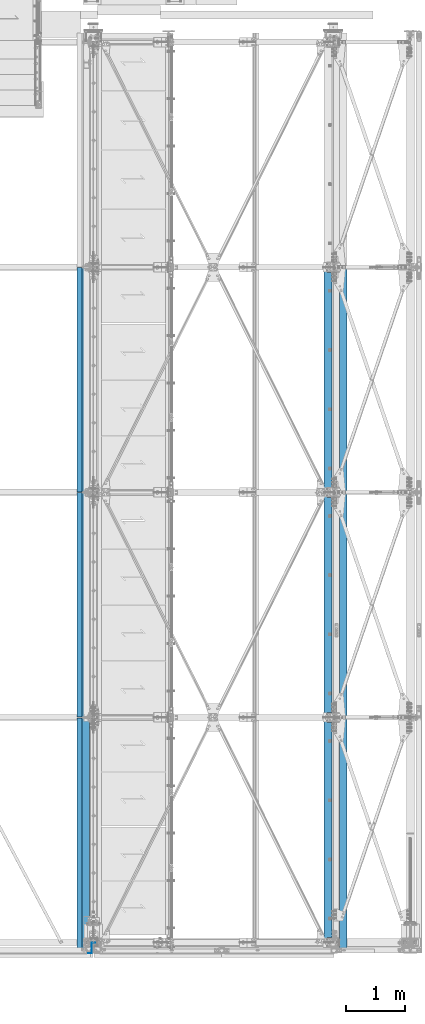
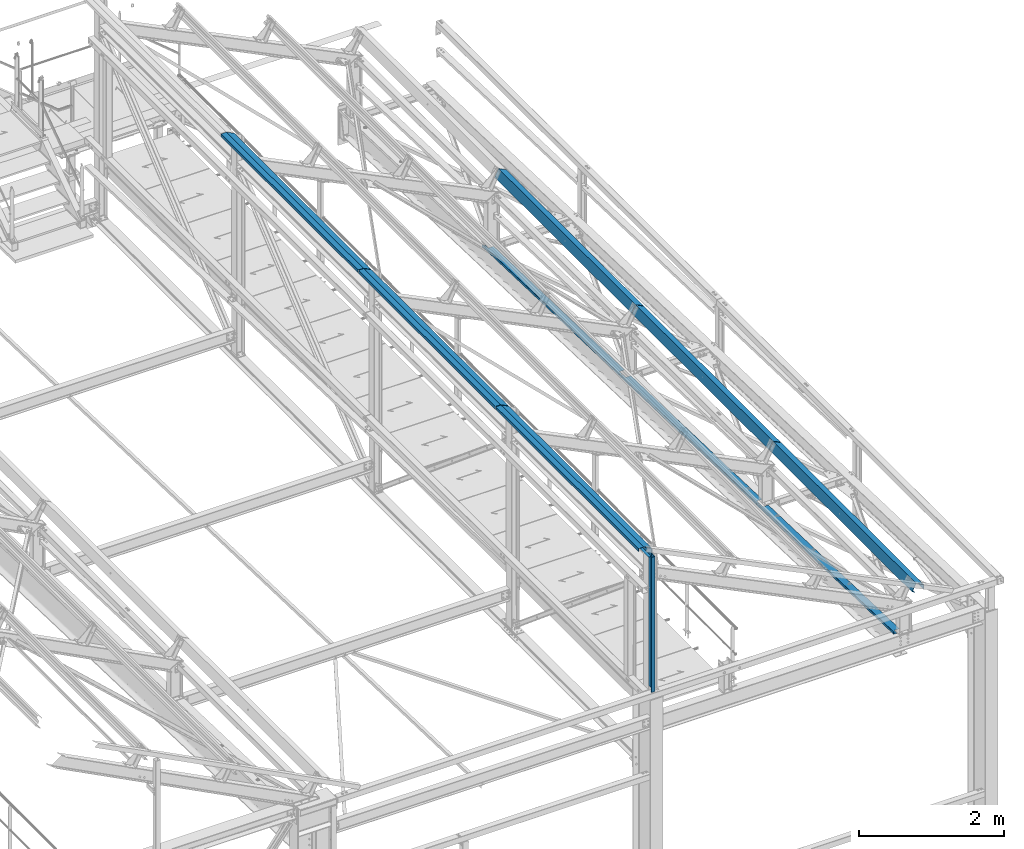
# One storey, part 351 of 496: 10 beams, 10 elements without a shape of their own.
"""IFC2X3 building model written with IfcOpenShell, lengths in millimetres."""

import ifcopenshell
import ifcopenshell.guid

model = None  # the IFC model being written
_history = None  # IfcOwnerHistory: only IFC2X3 demands one
_inside = {}  # id of a spatial element -> (the spatial element, [elements in it])
_under = {}  # id of a project, library or spatial element -> (it, [spatial elements below it])
_declared = {}  # id of a project -> (the project, [libraries it declares])
_typed = {}  # id of a type object -> (the type object, [elements of that type])
_made_of = {}  # id of a material, layer set ... -> (it, [elements and type objects made of it])


def new_model(schema):
    """Start an empty IFC model of exactly this schema.

    Asked for "IFC4X3", IfcOpenShell would pick the latest addendum, in which some entities
    have other attributes; the version numbers below select the first issue.
    IFC2X3 requires an IfcOwnerHistory on every rooted entity: one is made here for all.
    """
    global model, _history
    if schema == "IFC4X3":
        model = ifcopenshell.file(schema_version=(4, 3, 0, 0))
    else:
        model = ifcopenshell.file(schema=schema)
    _inside.clear()
    _under.clear()
    _declared.clear()
    _typed.clear()
    _made_of.clear()
    _history = None
    if model.schema == "IFC2X3":
        org = make("IfcOrganization", Name="unknown")
        user = make(
            "IfcPersonAndOrganization",
            ThePerson=make("IfcPerson", FamilyName="unknown"),
            TheOrganization=org,
        )
        app = make(
            "IfcApplication",
            ApplicationDeveloper=org,
            Version="unknown",
            ApplicationFullName="unknown",
            ApplicationIdentifier="unknown",
        )
        _history = make(
            "IfcOwnerHistory",
            OwningUser=user,
            OwningApplication=app,
            ChangeAction="ADDED",
            CreationDate=0,
        )
    return model


def make(cls, **values):
    """One entity of the class cls with the attributes given. An attribute that is None is left unset."""
    return model.create_entity(
        cls, **{name: value for name, value in values.items() if value is not None}
    )


def rooted(cls, **values):
    """An entity with a GlobalId (a new one), such as an element, a storey or a relation."""
    return make(cls, GlobalId=ifcopenshell.guid.new(), OwnerHistory=_history, **values)


def si_unit(unit_type, name, prefix=None):
    """IfcSIUnit, for example si_unit("LENGTHUNIT", "METRE", prefix="MILLI")."""
    return make("IfcSIUnit", UnitType=unit_type, Prefix=prefix, Name=name)


def assignment(units):
    """IfcUnitAssignment: the units of a project."""
    return None if units is None else make("IfcUnitAssignment", Units=units)


def point(xyz):
    """IfcCartesianPoint."""
    return None if xyz is None else make("IfcCartesianPoint", Coordinates=xyz)


def direction(xyz):
    """IfcDirection."""
    return None if xyz is None else make("IfcDirection", DirectionRatios=xyz)


def frame(location, z_axis=None, x_axis=None):
    """IfcAxis2Placement3D, a coordinate frame: its origin and axes. An axis left out is left unset."""
    return make(
        "IfcAxis2Placement3D",
        Location=point(location),
        Axis=direction(z_axis),
        RefDirection=direction(x_axis),
    )


def origin_with_axes():
    """The frame at (0, 0, 0) with the z axis (0, 0, 1) and the x axis (1, 0, 0) written out."""
    return frame((0.0, 0.0, 0.0), z_axis=(0.0, 0.0, 1.0), x_axis=(1.0, 0.0, 0.0))


def place(relative_to, where):
    """IfcLocalPlacement: puts the frame where relative to a parent placement (None: the world)."""
    return make(
        "IfcLocalPlacement", PlacementRelTo=relative_to, RelativePlacement=where
    )


def context(
    kind, dimensions, precision=None, world=None, true_north=None, identifier=None
):
    """IfcGeometricRepresentationContext, for example the 3D "Model" context."""
    return make(
        "IfcGeometricRepresentationContext",
        ContextIdentifier=identifier,
        ContextType=kind,
        CoordinateSpaceDimension=dimensions,
        Precision=precision,
        WorldCoordinateSystem=world,
        TrueNorth=true_north,
    )


def subcontext(parent, identifier, kind, view, scale=None):
    """IfcGeometricRepresentationSubContext, for example "Body" below "Model"."""
    return make(
        "IfcGeometricRepresentationSubContext",
        ContextIdentifier=identifier,
        ContextType=kind,
        ParentContext=parent,
        TargetScale=scale,
        TargetView=view,
    )


def project(units=None, contexts=None):
    """IfcProject with its units and contexts."""
    return rooted(
        "IfcProject",
        Name="project",
        RepresentationContexts=contexts,
        UnitsInContext=assignment(units),
    )


def spatial(cls, under=None, at=None, **own):
    """A site, building, storey or space (cls), placed at a placement, below another one or the project."""
    s = rooted(cls, ObjectPlacement=at, **own)
    if under is not None:
        _under.setdefault(under.id(), (under, []))[1].append(s)
    return s


def faces_of(points, faces, orient=None, outer=None):
    """IfcFace entities. A face is a list of loops; a loop is a list of indices into points, from 0.

    orient and outer hold one flag for each loop. By default every Orientation is true, the
    first loop of a face is its IfcFaceOuterBound and the others are IfcFaceBound.
    """
    made = []
    for i, loops in enumerate(faces):
        bounds = []
        for j, loop in enumerate(loops):
            is_outer = j == 0 if outer is None else outer[i][j]
            bounds.append(
                make(
                    "IfcFaceOuterBound" if is_outer else "IfcFaceBound",
                    Bound=make("IfcPolyLoop", Polygon=[points[k] for k in loop]),
                    Orientation=True if orient is None else orient[i][j],
                )
            )
        made.append(make("IfcFace", Bounds=bounds))
    return made


def faceted_brep(points, faces, orient=None, outer=None, voids=None):
    """IfcFacetedBrep: a solid bounded by flat faces; with voids (closed shells), ...WithVoids."""
    shared = [point(p) for p in points]
    hull = make("IfcClosedShell", CfsFaces=faces_of(shared, faces, orient, outer))
    if voids is None:
        return make("IfcFacetedBrep", Outer=hull)
    return make(
        "IfcFacetedBrepWithVoids",
        Outer=hull,
        Voids=[
            make(cls, CfsFaces=faces_of(shared, fs, o, b)) for cls, fs, o, b in voids
        ],
    )


def shape(context_of_items, identifier, shape_type, items):
    """IfcShapeRepresentation: the items that make up one representation, for example the "Body"."""
    return make(
        "IfcShapeRepresentation",
        ContextOfItems=context_of_items,
        RepresentationIdentifier=identifier,
        RepresentationType=shape_type,
        Items=items,
    )


def material(Name=None, Category=None):
    """IfcMaterial."""
    return make("IfcMaterial", Name=Name, Category=Category)


def made_of(thing, what):
    """Note that an element or type object is made of a material, layer set ...; save() writes the relation."""
    if what is not None:
        _made_of.setdefault(what.id(), (what, []))[1].append(thing)
    return thing


def type_object(cls, material=None, **own):
    """A type object (cls), such as IfcWallType, which elements share."""
    return made_of(rooted(cls, **own), material)


def element(
    cls,
    number,
    at=None,
    inside=None,
    cuts=None,
    type_object=None,
    material=None,
    context=None,
    identifier="Body",
    shape_type=None,
    held_by="IfcProductDefinitionShape",
    body=None,
    shapes=None,
    **own,
):
    """One element of the class cls, such as IfcWall. Its Tag is "e" and its number.

    at: its placement. inside: the storey or other place that contains it. cuts: it is an
    opening in that element (IfcRelVoidsElement). A single representation is given by context,
    identifier, shape_type and body (its items); several are given by shapes. held_by: the class
    of the entity that holds the representations. save() writes the other relations.
    """
    e = rooted(cls, Tag="e%d" % number, ObjectPlacement=at, **own)
    if body is not None:
        shapes = [shape(context, identifier, shape_type, body)]
    if shapes is not None:
        e.Representation = make(held_by, Representations=shapes)
    if inside is not None:
        _inside.setdefault(inside.id(), (inside, []))[1].append(e)
    if cuts is not None:
        rooted(
            "IfcRelVoidsElement", RelatingBuildingElement=cuts, RelatedOpeningElement=e
        )
    if type_object is not None:
        _typed.setdefault(type_object.id(), (type_object, []))[1].append(e)
    return made_of(e, material)


def aggregate(whole, parts):
    """IfcRelAggregates: a whole, such as a stair, and the parts it consists of."""
    return rooted("IfcRelAggregates", RelatingObject=whole, RelatedObjects=parts)


def save(model, path):
    """Write the relations noted so far, then the file.

    IfcRelAggregates (storeys below a building ...), IfcRelContainedInSpatialStructure (elements
    in a storey), IfcRelDefinesByType, IfcRelAssociatesMaterial and IfcRelDeclares: one each for
    every whole, place, type object, material and project.
    """
    for whole, parts in _under.values():
        aggregate(whole, parts)
    for where, things in _inside.values():
        rooted(
            "IfcRelContainedInSpatialStructure",
            RelatedElements=things,
            RelatingStructure=where,
        )
    for kind, things in _typed.values():
        rooted("IfcRelDefinesByType", RelatedObjects=things, RelatingType=kind)
    for what, things in _made_of.values():
        rooted("IfcRelAssociatesMaterial", RelatedObjects=things, RelatingMaterial=what)
    for by, libraries in _declared.values():
        rooted("IfcRelDeclares", RelatingContext=by, RelatedDefinitions=libraries)
    model.write(path)


model = new_model("IFC2X3")

# Units and contexts
model_context = context("Model", 3, precision=1e-05, world=origin_with_axes())
body_context = subcontext(model_context, "Body", "Model", "MODEL_VIEW")
ifc_project = project(units=[si_unit("LENGTHUNIT", "METRE", prefix="MILLI"), si_unit("AREAUNIT", "SQUARE_METRE"), si_unit("VOLUMEUNIT", "CUBIC_METRE"), si_unit("MASSUNIT", "GRAM", prefix="KILO"), si_unit("TIMEUNIT", "SECOND"), si_unit("PLANEANGLEUNIT", "RADIAN"), si_unit("SOLIDANGLEUNIT", "STERADIAN"), si_unit("THERMODYNAMICTEMPERATUREUNIT", "DEGREE_CELSIUS"), si_unit("LUMINOUSINTENSITYUNIT", "LUMEN")], contexts=[model_context])

# Site, building, storey
site_placement = place(None, origin_with_axes())
site = spatial("IfcSite", under=ifc_project, at=site_placement, CompositionType="ELEMENT")
building_placement = place(site_placement, origin_with_axes())
building = spatial("IfcBuilding", under=site, at=building_placement, Name="Undefined", CompositionType="ELEMENT")
storey_placement = place(building_placement, origin_with_axes())
storey = spatial("IfcBuildingStorey", under=building, at=storey_placement, Name="Undefined", CompositionType="ELEMENT", Elevation=0.0)

# Assembly, beam
assembly_1_placement = place(storey_placement, origin_with_axes())
assembly_1 = element("IfcElementAssembly", 1, at=assembly_1_placement, inside=storey, Name="SHED", AssemblyPlace="NOTDEFINED", PredefinedType="NOTDEFINED")
ifc_material = material(Name="Undefined/S235-E24")
beam_type_1 = type_object("IfcBeamType", PredefinedType="NOTDEFINED")
beam_1_placement = place(assembly_1_placement, frame((38418.1250345939, 9500.00038595282, 8769.23312698683), z_axis=(0.0, 1.0, 0.0), x_axis=(-0.897398510539055, -1.29999898490537e-08, 0.441220934773368)))
beam_1 = element("IfcBeam", 2, at=beam_1_placement, type_object=beam_type_1, material=ifc_material, Name="SHED", context=body_context, shape_type="Brep", body=[
    faceted_brep([(-3.49427864421159e-08, -1.49999999999636, -1895.0), (-3.52956703864038e-08, -1.5, 1895.0), (3.49573383573443e-08, 1.5, 1895.0), (3.53102223016322e-08, 1.5, -1895.0), (47.0000011861484, 1.499998899395, 1895.0), (47.0000011898519, 1.49999889939863, -1895.0), (50.0000011927114, -1.50000117085074, -1895.0), (50.0000011890152, -1.50000117085438, 1895.0), (47.000001059947, 135.500002207569, 1895.00000000012), (47.0000010603762, 135.500002214732, -1894.99999999988), (50.0000010575095, 138.500002217588, -1894.99999999987), (50.0000010570839, 138.500002210421, 1895.00000000013), (-88.1320086650667, 135.500006400751, 1895.00000000041), (-88.1320086733285, 135.500006406346, -1894.99999999959), (-90.0000023299144, 138.50000208251, -1894.99999999975), (-90.0000023251705, 138.500002079061, 1895.00000000025), (-122.605485965658, 65.3844594190341, 1895.00000000043), (-122.605485972435, 65.3844594213988, -1894.99999999957), (-125.297681497275, 66.7081222233501, 1895.00000000044), (-125.297681504053, 66.7081222257148, -1894.99999999956)], [[[0, 1, 2, 3]], [[3, 2, 4, 5]], [[1, 0, 6, 7]], [[5, 4, 8, 9]], [[7, 6, 10, 11]], [[9, 8, 12, 13]], [[11, 10, 14, 15]], [[13, 12, 16, 17]], [[12, 8, 4, 2, 1, 7, 11, 15, 18, 16]], [[15, 14, 19, 18]], [[14, 10, 6, 0, 3, 5, 9, 13, 17, 19]], [[18, 19, 17, 16]]]),
])
aggregate(assembly_1, [beam_1])

assembly_2_placement = place(storey_placement, origin_with_axes())
assembly_2 = element("IfcElementAssembly", 3, at=assembly_2_placement, inside=storey, Name="SHED", AssemblyPlace="NOTDEFINED", PredefinedType="NOTDEFINED")
beam_2_placement = place(assembly_2_placement, frame((38418.1250345939, 5700.00038595282, 8769.23312698683), z_axis=(0.0, 1.0, 0.0), x_axis=(-0.897398510539055, -1.29999898490537e-08, 0.441220934773368)))
beam_2 = element("IfcBeam", 4, at=beam_2_placement, type_object=beam_type_1, material=ifc_material, Name="SHED", context=body_context, shape_type="Brep", body=[
    faceted_brep([(-3.49427864421159e-08, -1.49999999999636, -1895.0), (-3.52956703864038e-08, -1.5, 1895.0), (3.49573383573443e-08, 1.5, 1895.0), (3.53102223016322e-08, 1.5, -1895.0), (47.0000011861484, 1.499998899395, 1895.0), (47.0000011898519, 1.49999889939863, -1895.0), (50.0000011927114, -1.50000117085074, -1895.0), (50.0000011890152, -1.50000117085438, 1895.0), (47.000001059947, 135.500002207569, 1895.00000000012), (47.0000010603762, 135.500002214732, -1894.99999999988), (50.0000010575095, 138.500002217588, -1894.99999999987), (50.0000010570839, 138.500002210421, 1895.00000000013), (-88.1320086650667, 135.500006400751, 1895.00000000041), (-88.1320086733285, 135.500006406346, -1894.99999999959), (-90.0000023299144, 138.50000208251, -1894.99999999975), (-90.0000023251705, 138.500002079061, 1895.00000000025), (-122.605485965658, 65.3844594190341, 1895.00000000043), (-122.605485972435, 65.3844594213988, -1894.99999999957), (-125.297681497275, 66.7081222233501, 1895.00000000044), (-125.297681504053, 66.7081222257148, -1894.99999999956)], [[[0, 1, 2, 3]], [[3, 2, 4, 5]], [[1, 0, 6, 7]], [[5, 4, 8, 9]], [[7, 6, 10, 11]], [[9, 8, 12, 13]], [[11, 10, 14, 15]], [[13, 12, 16, 17]], [[12, 8, 4, 2, 1, 7, 11, 15, 18, 16]], [[15, 14, 19, 18]], [[14, 10, 6, 0, 3, 5, 9, 13, 17, 19]], [[18, 19, 17, 16]]]),
])
aggregate(assembly_2, [beam_2])

assembly_3_placement = place(storey_placement, origin_with_axes())
assembly_3 = element("IfcElementAssembly", 5, at=assembly_3_placement, inside=storey, Name="SHED", AssemblyPlace="NOTDEFINED", PredefinedType="NOTDEFINED")
beam_3_placement = place(assembly_3_placement, frame((34004.99999895, 5700.00031982999, 11002.6130365134), z_axis=(0.0, 1.0, 0.0), x_axis=(0.0, 0.0, 1.0)))
beam_3 = element("IfcBeam", 6, at=beam_3_placement, type_object=beam_type_1, material=ifc_material, Name="SHED", context=body_context, shape_type="Brep", body=[
    faceted_brep([(-3.49427864421159e-08, -1.49999999999636, -1895.0), (-3.52956703864038e-08, -1.5, 1895.0), (3.49573383573443e-08, 1.5, 1895.0), (3.53102223016322e-08, 1.5, -1895.0), (47.0000011861484, 1.499998899395, 1895.0), (47.0000011898519, 1.49999889939863, -1895.0), (50.0000011927114, -1.50000117085074, -1895.0), (50.0000011890152, -1.50000117085438, 1895.0), (47.0, 82.166592196445, 1895.0), (47.0, 82.166592196445, -1895.0), (50.0, 82.8642120361328, -1895.0), (50.0, 82.8642120361328, 1895.0), (-13.6389276254631, 205.5, 1895.0), (-13.6389276254631, 205.5, -1895.0), (-11.7709312438965, 208.5, -1895.0), (-11.7709312438965, 208.5, 1895.0), (-148.770935058594, 205.5, 1895.0), (-148.770935058594, 205.5, -1895.0), (-151.770935058594, 208.5, -1895.0), (-151.770935058594, 208.5, 1895.0), (-148.770935058594, 158.5, 1895.0), (-148.770935058594, 158.5, -1895.0), (-151.770935058594, 158.5, 1895.0), (-151.770935058594, 158.5, -1895.0)], [[[0, 1, 2, 3]], [[3, 2, 4, 5]], [[1, 0, 6, 7]], [[5, 4, 8, 9]], [[7, 6, 10, 11]], [[9, 8, 12, 13]], [[11, 10, 14, 15]], [[13, 12, 16, 17]], [[15, 14, 18, 19]], [[17, 16, 20, 21]], [[16, 12, 8, 4, 2, 1, 7, 11, 15, 19, 22, 20]], [[19, 18, 23, 22]], [[18, 14, 10, 6, 0, 3, 5, 9, 13, 17, 21, 23]], [[22, 23, 21, 20]]]),
])
aggregate(assembly_3, [beam_3])

assembly_4_placement = place(storey_placement, origin_with_axes())
assembly_4 = element("IfcElementAssembly", 7, at=assembly_4_placement, inside=storey, Name="SHED", AssemblyPlace="NOTDEFINED", PredefinedType="NOTDEFINED")
beam_4_placement = place(assembly_4_placement, frame((34004.99999895, 9500.00031982999, 11002.6130365103), z_axis=(0.0, 1.0, 0.0), x_axis=(0.0, 0.0, 1.0)))
beam_4 = element("IfcBeam", 8, at=beam_4_placement, type_object=beam_type_1, material=ifc_material, Name="SHED", context=body_context, shape_type="Brep", body=[
    faceted_brep([(-3.49427864421159e-08, -1.49999999999636, -1895.0), (-3.52956703864038e-08, -1.5, 1895.0), (3.49573383573443e-08, 1.5, 1895.0), (3.53102223016322e-08, 1.5, -1895.0), (47.0000011861484, 1.499998899395, 1895.0), (47.0000011898519, 1.49999889939863, -1895.0), (50.0000011927114, -1.50000117085074, -1895.0), (50.0000011890152, -1.50000117085438, 1895.0), (47.0, 82.166592196445, 1895.0), (47.0, 82.166592196445, -1895.0), (50.0, 82.8642120361328, -1895.0), (50.0, 82.8642120361328, 1895.0), (-13.6389276254631, 205.5, 1895.0), (-13.6389276254631, 205.5, -1895.0), (-11.7709312438965, 208.5, -1895.0), (-11.7709312438965, 208.5, 1895.0), (-148.770935058594, 205.5, 1895.0), (-148.770935058594, 205.5, -1895.0), (-151.770935058594, 208.5, -1895.0), (-151.770935058594, 208.5, 1895.0), (-148.770935058594, 158.5, 1895.0), (-148.770935058594, 158.5, -1895.0), (-151.770935058594, 158.5, 1895.0), (-151.770935058594, 158.5, -1895.0)], [[[0, 1, 2, 3]], [[3, 2, 4, 5]], [[1, 0, 6, 7]], [[5, 4, 8, 9]], [[7, 6, 10, 11]], [[9, 8, 12, 13]], [[11, 10, 14, 15]], [[13, 12, 16, 17]], [[15, 14, 18, 19]], [[17, 16, 20, 21]], [[16, 12, 8, 4, 2, 1, 7, 11, 15, 19, 22, 20]], [[19, 18, 23, 22]], [[18, 14, 10, 6, 0, 3, 5, 9, 13, 17, 21, 23]], [[22, 23, 21, 20]]]),
])
aggregate(assembly_4, [beam_4])

assembly_5_placement = place(storey_placement, origin_with_axes())
assembly_5 = element("IfcElementAssembly", 9, at=assembly_5_placement, inside=storey, Name="POUTRE", AssemblyPlace="NOTDEFINED", PredefinedType="NOTDEFINED")
beam_type_2 = type_object("IfcBeamType", PredefinedType="NOTDEFINED")
beam_5_placement = place(assembly_5_placement, frame((38309.9999999999, 1899.71695010422, 7991.29997216435), z_axis=(0.0, 0.999506556345274, -0.0314108870109058), x_axis=(-1.0, 0.0, 0.0)))
beam_5 = element("IfcBeam", 10, at=beam_5_placement, type_object=beam_type_2, material=ifc_material, Name="POUTRE", context=body_context, shape_type="Brep", body=[
    faceted_brep([(84.9999999979264, 0.999999999923602, 1895.93800542073), (84.9999999999563, 0.999999999923602, 1815.93800543636), (84.9999999999563, -1.00000000007185, 1815.93800543636), (84.9999999979264, -1.00000000007731, 1895.93800542073), (7.27595761418343e-12, 1.00000000000182, 1815.93800543633), (0.0, -0.999999999999091, 1815.93800543633), (137.999999999782, 39.0000003423174, -1895.93800544089), (137.999999999767, 0.999999999872671, -1895.9380054409), (137.999999999796, 0.999999999875399, 1895.93800542073), (137.999999999782, 39.0000003423456, 1895.93800542075), (139.999999999782, 39.0000003423174, -1895.93800544089), (139.999999999782, 39.0000003423456, 1895.93800542075), (139.999999999767, -1.00000000012824, -1895.93800544091), (139.999999999796, -1.00000000012733, 1895.93800542073), (85.0000000000728, -1.00000000007822, -1895.93800544091), (85.0000000000728, 0.999999999920874, -1895.9380054409), (85.0000000000582, -1.00000000007913, -1815.93800540536), (85.0000000000582, 0.999999999921783, -1815.93800540536), (0.0, 1.0, -1815.93800540536), (-7.27595761418343e-12, -1.00000000000091, -1815.93800540536)], [[[0, 1, 2, 3]], [[4, 5, 2, 1]], [[6, 7, 8, 9]], [[10, 6, 9, 11]], [[12, 10, 11, 13]], [[7, 6, 10, 12, 14, 15]], [[15, 14, 16, 17]], [[18, 17, 16, 19]], [[0, 8, 7, 15, 17, 18, 4, 1]], [[13, 11, 9, 8, 0, 3]], [[19, 16, 14, 12, 13, 3, 2, 5]], [[18, 19, 5, 4]]]),
])
aggregate(assembly_5, [beam_5])

assembly_6_placement = place(storey_placement, origin_with_axes())
assembly_6 = element("IfcElementAssembly", 11, at=assembly_6_placement, inside=storey, Name="POUTRE", AssemblyPlace="NOTDEFINED", PredefinedType="NOTDEFINED")
beam_6_placement = place(assembly_6_placement, frame((38309.9999999999, 5699.71696464998, 7871.88016099719), z_axis=(0.0, 0.999506556345274, -0.0314108870109058), x_axis=(-1.0, 0.0, 0.0)))
beam_6 = element("IfcBeam", 12, at=beam_6_placement, type_object=beam_type_2, material=ifc_material, Name="POUTRE", context=body_context, shape_type="Brep", body=[
    faceted_brep([(84.9999999979264, 0.999999999923602, 1895.93800542073), (84.9999999999563, 0.999999999923602, 1815.93800543636), (84.9999999999563, -1.00000000007185, 1815.93800543636), (84.9999999979264, -1.00000000007731, 1895.93800542073), (7.27595761418343e-12, 1.00000000000182, 1815.93800543633), (0.0, -0.999999999999091, 1815.93800543633), (137.999999999782, 39.0000003423174, -1895.93800544089), (137.999999999767, 0.999999999872671, -1895.9380054409), (137.999999999796, 0.999999999875399, 1895.93800542073), (137.999999999782, 39.0000003423456, 1895.93800542075), (139.999999999782, 39.0000003423174, -1895.93800544089), (139.999999999782, 39.0000003423456, 1895.93800542075), (139.999999999767, -1.00000000012824, -1895.93800544091), (139.999999999796, -1.00000000012733, 1895.93800542073), (85.0000000000728, -1.00000000007822, -1895.93800544091), (85.0000000000728, 0.999999999920874, -1895.9380054409), (85.0000000000582, -1.00000000007913, -1815.93800540536), (85.0000000000582, 0.999999999921783, -1815.93800540536), (0.0, 1.0, -1815.93800540536), (-7.27595761418343e-12, -1.00000000000091, -1815.93800540536)], [[[0, 1, 2, 3]], [[4, 5, 2, 1]], [[6, 7, 8, 9]], [[10, 6, 9, 11]], [[12, 10, 11, 13]], [[7, 6, 10, 12, 14, 15]], [[15, 14, 16, 17]], [[18, 17, 16, 19]], [[0, 8, 7, 15, 17, 18, 4, 1]], [[13, 11, 9, 8, 0, 3]], [[19, 16, 14, 12, 13, 3, 2, 5]], [[18, 19, 5, 4]]]),
])
aggregate(assembly_6, [beam_6])

assembly_7_placement = place(storey_placement, origin_with_axes())
assembly_7 = element("IfcElementAssembly", 13, at=assembly_7_placement, inside=storey, Name="POUTRE", AssemblyPlace="NOTDEFINED", PredefinedType="NOTDEFINED")
beam_7_placement = place(assembly_7_placement, frame((38309.9999999999, 9499.71697919142, 7752.46034983002), z_axis=(0.0, 0.999506556345274, -0.0314108870109058), x_axis=(-1.0, 0.0, 0.0)))
beam_7 = element("IfcBeam", 14, at=beam_7_placement, type_object=beam_type_2, material=ifc_material, Name="POUTRE", context=body_context, shape_type="Brep", body=[
    faceted_brep([(84.9999999979264, 0.999999999923602, 1895.93800542073), (84.9999999999563, 0.999999999923602, 1815.93800543636), (84.9999999999563, -1.00000000007185, 1815.93800543636), (84.9999999979264, -1.00000000007731, 1895.93800542073), (7.27595761418343e-12, 1.00000000000182, 1815.93800543633), (0.0, -0.999999999999091, 1815.93800543633), (137.999999999782, 39.0000003423174, -1895.93800544089), (137.999999999767, 0.999999999872671, -1895.9380054409), (137.999999999796, 0.999999999875399, 1895.93800542073), (137.999999999782, 39.0000003423456, 1895.93800542075), (139.999999999782, 39.0000003423174, -1895.93800544089), (139.999999999782, 39.0000003423456, 1895.93800542075), (139.999999999767, -1.00000000012824, -1895.93800544091), (139.999999999796, -1.00000000012733, 1895.93800542073), (85.0000000000728, -1.00000000007822, -1895.93800544091), (85.0000000000728, 0.999999999920874, -1895.9380054409), (85.0000000000582, -1.00000000007913, -1815.93800540536), (85.0000000000582, 0.999999999921783, -1815.93800540536), (0.0, 1.0, -1815.93800540536), (-7.27595761418343e-12, -1.00000000000091, -1815.93800540536)], [[[0, 1, 2, 3]], [[4, 5, 2, 1]], [[6, 7, 8, 9]], [[10, 6, 9, 11]], [[12, 10, 11, 13]], [[7, 6, 10, 12, 14, 15]], [[15, 14, 16, 17]], [[18, 17, 16, 19]], [[0, 8, 7, 15, 17, 18, 4, 1]], [[13, 11, 9, 8, 0, 3]], [[19, 16, 14, 12, 13, 3, 2, 5]], [[18, 19, 5, 4]]]),
])
aggregate(assembly_7, [beam_7])

assembly_8_placement = place(storey_placement, origin_with_axes())
assembly_8 = element("IfcElementAssembly", 15, at=assembly_8_placement, inside=storey, AssemblyPlace="NOTDEFINED", PredefinedType="NOTDEFINED")
beam_type_3 = type_object("IfcBeamType", PredefinedType="NOTDEFINED")
beam_8_placement = place(assembly_8_placement, frame((34310.0000001827, -4.25, 9710.0000000118), z_axis=(0.0, 0.0, 1.0), x_axis=(-1.0, 0.0, 0.0)))
beam_8 = element("IfcBeam", 16, at=beam_8_placement, type_object=beam_type_3, material=ifc_material, context=body_context, shape_type="Brep", body=[
    faceted_brep([(0.0, -1.5, -1140.0), (0.0, -1.5, 1140.0), (0.0, 1.5, 1140.0), (0.0, 1.5, -1140.0), (56.9999998506973, 1.5, 1140.0), (56.9999998506973, 1.5, -1140.0), (59.9999998506973, -1.5, -1140.0), (59.9999998506973, -1.5, 1140.0), (56.9999998506973, 175.75, 1140.0), (56.9999998506973, 175.75, -1140.0), (59.9999998506973, 172.75, -1140.0), (59.9999998506973, 172.75, 1140.0), (117.0, 175.75, 1140.0), (117.0, 175.75, -1140.0), (117.0, 172.75, 1140.0), (117.0, 172.75, -1140.0)], [[[0, 1, 2, 3]], [[3, 2, 4, 5]], [[1, 0, 6, 7]], [[5, 4, 8, 9]], [[7, 6, 10, 11]], [[9, 8, 12, 13]], [[8, 4, 2, 1, 7, 11, 14, 12]], [[11, 10, 15, 14]], [[10, 6, 0, 3, 5, 9, 13, 15]], [[14, 15, 13, 12]]]),
])
aggregate(assembly_8, [beam_8])

assembly_9_placement = place(storey_placement, origin_with_axes())
assembly_9 = element("IfcElementAssembly", 17, at=assembly_9_placement, inside=storey, Name="SHED", AssemblyPlace="NOTDEFINED", PredefinedType="NOTDEFINED")
beam_type_4 = type_object("IfcBeamType", PredefinedType="NOTDEFINED")
beam_9_placement = place(assembly_9_placement, frame((38418.1250345939, 1820.00038595282, 8769.23312698992), z_axis=(0.0, 1.0, 0.0), x_axis=(-0.897398510539055, -1.29999898490537e-08, 0.441220934773368)))
beam_9 = element("IfcBeam", 18, at=beam_9_placement, type_object=beam_type_4, material=ifc_material, Name="SHED", context=body_context, shape_type="Brep", body=[
    faceted_brep([(-4.57293936051428e-09, -1.5, -1975.0), (-2.82670953311026e-09, -1.49999999999636, 1975.0), (4.57293936051428e-09, 1.50000000000364, 1975.0), (2.82307155430317e-09, 1.50000000000364, -1975.0), (46.9999982244844, 1.49999988410855, 1974.99999999998), (46.9999982243717, 1.49999988410491, -1975.00000000002), (49.9999982228783, -1.50000012329474, -1975.00000000002), (49.9999982229929, -1.5000001232911, 1974.99999999998), (46.9999982920745, 135.499998582192, 1975.00000000004), (46.9999982902773, 135.499998584666, -1974.99999999997), (49.9999982917725, 138.499998490119, -1974.99999999997), (49.9999982935697, 138.499998487649, 1975.00000000004), (-88.1320086654086, 135.500006400631, 1975.00000000041), (-88.1320086729866, 135.500006406455, -1974.99999999959), (-90.0000045074175, 138.500002901914, -1974.99999999987), (-90.0000045038087, 138.50000290012, 1975.00000000013), (-122.605485965683, 65.3844594186739, 1975.00000000041), (-122.605485972406, 65.3844594217517, -1974.99999999959), (-125.297681497301, 66.7081222229899, 1975.00000000042), (-125.297681504031, 66.7081222260713, -1974.99999999958)], [[[0, 1, 2, 3]], [[3, 2, 4, 5]], [[1, 0, 6, 7]], [[5, 4, 8, 9]], [[7, 6, 10, 11]], [[9, 8, 12, 13]], [[11, 10, 14, 15]], [[13, 12, 16, 17]], [[12, 8, 4, 2, 1, 7, 11, 15, 18, 16]], [[15, 14, 19, 18]], [[14, 10, 6, 0, 3, 5, 9, 13, 17, 19]], [[18, 19, 17, 16]]]),
])
aggregate(assembly_9, [beam_9])

assembly_10_placement = place(storey_placement, origin_with_axes())
assembly_10 = element("IfcElementAssembly", 19, at=assembly_10_placement, inside=storey, Name="SHED", AssemblyPlace="NOTDEFINED", PredefinedType="NOTDEFINED")
beam_10_placement = place(assembly_10_placement, frame((34004.99999895, 1820.00031982999, 11002.6130365164), z_axis=(0.0, -1.0, 0.0), x_axis=(0.0, 0.0, 1.0)))
beam_10 = element("IfcBeam", 20, at=beam_10_placement, type_object=beam_type_4, material=ifc_material, Name="SHED", context=body_context, shape_type="Brep", body=[
    faceted_brep([(-4.57293936051428e-09, -1.5, -1975.0), (-2.82670953311026e-09, -1.49999999999636, 1975.0), (4.57293936051428e-09, 1.50000000000364, 1975.0), (2.82307155430317e-09, 1.50000000000364, -1975.0), (50.0, 1.5, 1975.0), (50.0, 1.5, -1975.0), (47.0, -1.5, -1975.0), (47.0, -1.5, 1975.0), (50.0, -82.8642120361328, 1975.0), (50.0, -82.8642120361328, -1975.0), (47.0, -82.166592196445, -1975.0), (47.0, -82.166592196445, 1975.0), (-11.7709312438965, -208.5, 1975.0), (-11.7709312438965, -208.5, -1975.0), (-13.6389276254631, -205.5, -1975.0), (-13.6389276254631, -205.5, 1975.0), (-151.770935058594, -208.5, 1975.0), (-151.770935058594, -208.5, -1975.0), (-148.770935058594, -205.5, -1975.0), (-148.770935058594, -205.5, 1975.0), (-151.770935058594, -158.5, 1975.0), (-151.770935058594, -158.5, -1975.0), (-148.770935058594, -158.5, 1975.0), (-148.770935058594, -158.5, -1975.0)], [[[0, 1, 2, 3]], [[3, 2, 4, 5]], [[1, 0, 6, 7]], [[5, 4, 8, 9]], [[7, 6, 10, 11]], [[9, 8, 12, 13]], [[11, 10, 14, 15]], [[13, 12, 16, 17]], [[15, 14, 18, 19]], [[17, 16, 20, 21]], [[16, 12, 8, 4, 2, 1, 7, 11, 15, 19, 22, 20]], [[19, 18, 23, 22]], [[18, 14, 10, 6, 0, 3, 5, 9, 13, 17, 21, 23]], [[22, 23, 21, 20]]]),
])
aggregate(assembly_10, [beam_10])

save(model, "model.ifc")
